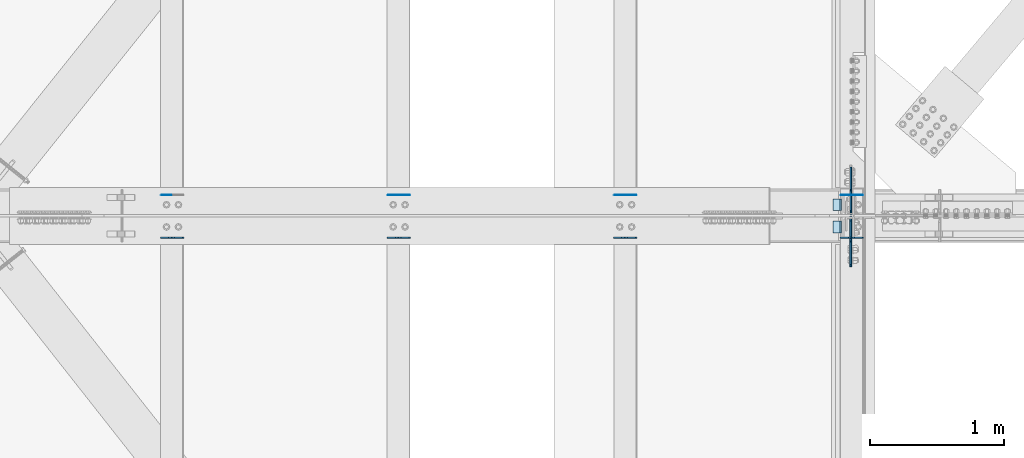
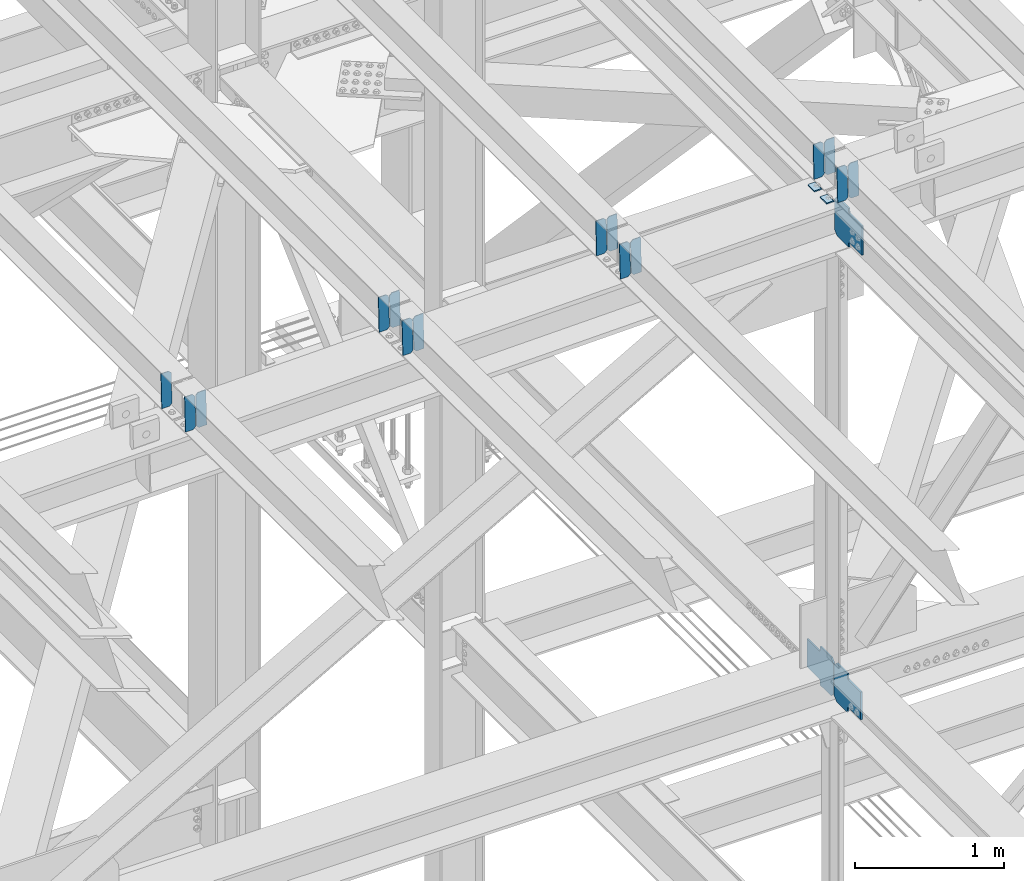
# One storey, part 3489 of 3843: 20 plates, 10 elements without a shape of their own.
"""IFC2X3 building model written with IfcOpenShell, lengths in millimetres."""

from ifc_helpers import new_model, si_unit, frame, origin_with_axes, place, context, subcontext, project, spatial, faceted_brep, material, type_object, element, aggregate, save


model = new_model("IFC2X3")

# Units and contexts
model_context = context("Model", 3, precision=1e-05, world=origin_with_axes())
body_context = subcontext(model_context, "Body", "Model", "MODEL_VIEW")
ifc_project = project(units=[si_unit("LENGTHUNIT", "METRE", prefix="MILLI"), si_unit("AREAUNIT", "SQUARE_METRE"), si_unit("VOLUMEUNIT", "CUBIC_METRE"), si_unit("MASSUNIT", "GRAM", prefix="KILO"), si_unit("TIMEUNIT", "SECOND"), si_unit("PLANEANGLEUNIT", "RADIAN"), si_unit("SOLIDANGLEUNIT", "STERADIAN"), si_unit("THERMODYNAMICTEMPERATUREUNIT", "DEGREE_CELSIUS"), si_unit("LUMINOUSINTENSITYUNIT", "LUMEN")], contexts=[model_context])

# Site, building, storey
site_placement = place(None, origin_with_axes())
site = spatial("IfcSite", under=ifc_project, at=site_placement, CompositionType="ELEMENT")
building_placement = place(site_placement, origin_with_axes())
building = spatial("IfcBuilding", under=site, at=building_placement, Name="Undefined", CompositionType="ELEMENT")
storey_placement = place(building_placement, origin_with_axes())
storey = spatial("IfcBuildingStorey", under=building, at=storey_placement, Name="Undefined", CompositionType="ELEMENT", Elevation=0.0)

# Assembly, plates
assembly_1_placement = place(storey_placement, origin_with_axes())
assembly_1 = element("IfcElementAssembly", 1, at=assembly_1_placement, inside=storey, Name="BEAM", AssemblyPlace="NOTDEFINED", PredefinedType="RIGID_FRAME")
ifc_material = material(Name="STEEL/A572-50")
plate_type_1 = type_object("IfcPlateType", PredefinedType="NOTDEFINED")
plate_1_placement = place(assembly_1_placement, frame((75405.9964783262, 84140.0711060768, 46268.5763166903), z_axis=(-0.021152098282546, 0.00202235899982043, 0.99977422391374), x_axis=(-0.999776269341419, -4.278700010456e-05, -0.0211520550071887)))
plate_1 = element("IfcPlate", 2, at=plate_1_placement, type_object=plate_type_1, material=ifc_material, Name="PLATE", context=body_context, shape_type="Brep", body=[
    faceted_brep([(0.0, -3.17499999999927, 0.0), (6.83940015733242e-10, -3.17499999996653, 288.924999998613), (6.54836185276508e-10, 3.17500000001746, 288.924999998591), (0.0, 3.17499999999927, 0.0), (60.3250007643655, -3.17500000017753, 288.924999998606), (60.3250007643219, 3.17499999979918, 288.924999998584), (79.3750000013097, -3.17500000025029, 269.875000761494), (79.375000001266, 3.17499999972642, 269.875000761487), (79.375000000713, -3.17500000026484, 19.0499992370605), (79.3750000006985, 3.17499999971187, 19.0499992370533), (60.325000763667, -3.17500000020664, -1.45519152283669e-11), (60.3250007636234, 3.17499999977736, -3.63797880709171e-11)], [[[0, 1, 2, 3]], [[1, 4, 5, 2]], [[4, 6, 7, 5]], [[6, 8, 9, 7]], [[8, 10, 11, 9]], [[10, 0, 3, 11]], [[5, 7, 9, 11, 3, 2]], [[10, 8, 6, 4, 1, 0]]]),
])
plate_2_placement = place(assembly_1_placement, frame((75320.2906576359, 84140.0674381852, 46266.7630567993), z_axis=(-0.021152098282546, 0.00202235899982043, 0.99977422391374), x_axis=(-0.999776269341419, -4.278700010456e-05, -0.0211520550071887)))
plate_2 = element("IfcPlate", 3, at=plate_2_placement, type_object=plate_type_1, material=ifc_material, Name="PLATE", context=body_context, shape_type="Brep", body=[
    faceted_brep([(4.36557456851006e-11, -3.17499999998836, 19.0499992370969), (6.11180439591408e-10, -3.17499999996653, 269.875000761516), (5.96628524363041e-10, 3.17500000001746, 269.875000761502), (1.45519152283669e-11, 3.17499999998836, 19.0499992370824), (19.0499992376572, -3.17500000003201, 288.924999998606), (19.0499992376281, 3.1749999999447, 288.924999998584), (79.3750000013242, -3.17500000025029, 288.924999998591), (79.3750000013097, 3.1749999997337, 288.92499999857), (79.3750000006548, -3.17500000026484, -2.18278728425503e-11), (79.3750000006403, 3.17499999969732, -2.91038304567337e-11), (19.0499992370023, -3.17500000005384, 0.0), (19.0499992369587, 3.17499999992287, -1.45519152283669e-11)], [[[0, 1, 2, 3]], [[1, 4, 5, 2]], [[4, 6, 7, 5]], [[6, 8, 9, 7]], [[8, 10, 11, 9]], [[10, 0, 3, 11]], [[5, 7, 9, 11, 3, 2]], [[10, 8, 6, 4, 1, 0]]]),
])
aggregate(assembly_1, [plate_1, plate_2])

assembly_2_placement = place(storey_placement, origin_with_axes())
assembly_2 = element("IfcElementAssembly", 4, at=assembly_2_placement, inside=storey, Name="BEAM", AssemblyPlace="NOTDEFINED", PredefinedType="RIGID_FRAME")
plate_3_placement = place(assembly_2_placement, frame((75405.9964783329, 83821.1587138441, 46270.8205939202), z_axis=(-0.0211520977145119, 0.00680309599898463, 0.999753122849388), x_axis=(-0.999776269353437, -0.000143932000051449, -0.0211516080075169)))
plate_3 = element("IfcPlate", 5, at=plate_3_placement, type_object=plate_type_1, material=ifc_material, Name="PLATE", context=body_context, shape_type="Brep", body=[
    faceted_brep([(0.0, -3.17499999999927, 0.0), (6.83940015733242e-10, -3.17499999996653, 288.924999998613), (6.54836185276508e-10, 3.17500000001746, 288.924999998591), (0.0, 3.17499999999927, 0.0), (60.3250007643655, -3.17500000017753, 288.924999998606), (60.3250007643219, 3.17499999979918, 288.924999998584), (79.3750000013097, -3.17500000025029, 269.875000761494), (79.375000001266, 3.17499999972642, 269.875000761487), (79.375000000713, -3.17500000026484, 19.0499992370605), (79.3750000006985, 3.17499999971187, 19.0499992370533), (60.325000763667, -3.17500000020664, -1.45519152283669e-11), (60.3250007636234, 3.17499999977736, -3.63797880709171e-11)], [[[0, 1, 2, 3]], [[1, 4, 5, 2]], [[4, 6, 7, 5]], [[6, 8, 9, 7]], [[8, 10, 11, 9]], [[10, 0, 3, 11]], [[5, 7, 9, 11, 3, 2]], [[10, 8, 6, 4, 1, 0]]]),
])
plate_4_placement = place(assembly_2_placement, frame((75320.2906576427, 83821.1463752781, 46269.0073722994), z_axis=(-0.0211520977145119, 0.00680309599898463, 0.999753122849388), x_axis=(-0.999776269353437, -0.000143932000051449, -0.0211516080075169)))
plate_4 = element("IfcPlate", 6, at=plate_4_placement, type_object=plate_type_1, material=ifc_material, Name="PLATE", context=body_context, shape_type="Brep", body=[
    faceted_brep([(4.36557456851006e-11, -3.17499999998836, 19.0499992370969), (6.11180439591408e-10, -3.17499999996653, 269.875000761516), (5.96628524363041e-10, 3.17500000001746, 269.875000761502), (1.45519152283669e-11, 3.17499999998836, 19.0499992370824), (19.0499992376572, -3.17500000003201, 288.924999998606), (19.0499992376281, 3.1749999999447, 288.924999998584), (79.3750000013242, -3.17500000025029, 288.924999998591), (79.3750000013097, 3.1749999997337, 288.92499999857), (79.3750000006548, -3.17500000026484, -2.18278728425503e-11), (79.3750000006403, 3.17499999969732, -2.91038304567337e-11), (19.0499992370023, -3.17500000005384, 0.0), (19.0499992369587, 3.17499999992287, -1.45519152283669e-11)], [[[0, 1, 2, 3]], [[1, 4, 5, 2]], [[4, 6, 7, 5]], [[6, 8, 9, 7]], [[8, 10, 11, 9]], [[10, 0, 3, 11]], [[5, 7, 9, 11, 3, 2]], [[10, 8, 6, 4, 1, 0]]]),
])
aggregate(assembly_2, [plate_3, plate_4])

assembly_3_placement = place(storey_placement, origin_with_axes())
assembly_3 = element("IfcElementAssembly", 7, at=assembly_3_placement, inside=storey, Name="BEAM", AssemblyPlace="NOTDEFINED", PredefinedType="RIGID_FRAME")
plate_5_placement = place(assembly_3_placement, frame((77095.0964787, 84140.0262572137, 46305.9190726986), z_axis=(-0.021152097941289, 0.00217238000044017, 0.999773909200383), x_axis=(-0.999776269356297, -4.57939999836346e-05, -0.021152048007558)))
plate_5 = element("IfcPlate", 8, at=plate_5_placement, type_object=plate_type_1, material=ifc_material, Name="PLATE", context=body_context, shape_type="Brep", body=[
    faceted_brep([(0.0, -3.17499999999927, 0.0), (6.83940015733242e-10, -3.17499999996653, 288.924999998613), (6.54836185276508e-10, 3.17500000001746, 288.924999998591), (0.0, 3.17499999999927, 0.0), (60.3250007643655, -3.17500000017753, 288.924999998606), (60.3250007643219, 3.17499999979918, 288.924999998584), (79.3750000013097, -3.17500000025029, 269.875000761494), (79.375000001266, 3.17499999972642, 269.875000761487), (79.375000000713, -3.17500000026484, 19.0499992370605), (79.3750000006985, 3.17499999971187, 19.0499992370533), (60.325000763667, -3.17500000020664, -1.45519152283669e-11), (60.3250007636234, 3.17499999977736, -3.63797880709171e-11)], [[[0, 1, 2, 3]], [[1, 4, 5, 2]], [[4, 6, 7, 5]], [[6, 8, 9, 7]], [[8, 10, 11, 9]], [[10, 0, 3, 11]], [[5, 7, 9, 11, 3, 2]], [[10, 8, 6, 4, 1, 0]]]),
])
plate_6_placement = place(assembly_3_placement, frame((77009.3906580087, 84140.0223172339, 46304.1058133777), z_axis=(-0.021152097941289, 0.00217238000044017, 0.999773909200383), x_axis=(-0.999776269356297, -4.57939999836346e-05, -0.021152048007558)))
plate_6 = element("IfcPlate", 9, at=plate_6_placement, type_object=plate_type_1, material=ifc_material, Name="PLATE", context=body_context, shape_type="Brep", body=[
    faceted_brep([(4.36557456851006e-11, -3.17499999998836, 19.0499992370969), (6.11180439591408e-10, -3.17499999996653, 269.875000761516), (5.96628524363041e-10, 3.17500000001746, 269.875000761502), (1.45519152283669e-11, 3.17499999998836, 19.0499992370824), (19.0499992376572, -3.17500000003201, 288.924999998606), (19.0499992376281, 3.1749999999447, 288.924999998584), (79.3750000013242, -3.17500000025029, 288.924999998591), (79.3750000013097, 3.1749999997337, 288.92499999857), (79.3750000006548, -3.17500000026484, -2.18278728425503e-11), (79.3750000006403, 3.17499999969732, -2.91038304567337e-11), (19.0499992370023, -3.17500000005384, 0.0), (19.0499992369587, 3.17499999992287, -1.45519152283669e-11)], [[[0, 1, 2, 3]], [[1, 4, 5, 2]], [[4, 6, 7, 5]], [[6, 8, 9, 7]], [[8, 10, 11, 9]], [[10, 0, 3, 11]], [[5, 7, 9, 11, 3, 2]], [[10, 8, 6, 4, 1, 0]]]),
])

assembly_4_placement = place(storey_placement, origin_with_axes())
assembly_4 = element("IfcElementAssembly", 10, at=assembly_4_placement, inside=storey, Name="BEAM", AssemblyPlace="NOTDEFINED", PredefinedType="RIGID_FRAME")
plate_7_placement = place(assembly_4_placement, frame((77095.0964779665, 83821.2714259354, 46307.3053200419), z_axis=(-0.0211520979147317, 0.00640378100221278, 0.999755760344836), x_axis=(-0.999776269349201, -0.000135484000106306, -0.02115166400736)))
plate_7 = element("IfcPlate", 11, at=plate_7_placement, type_object=plate_type_1, material=ifc_material, Name="PLATE", context=body_context, shape_type="Brep", body=[
    faceted_brep([(0.0, -3.17499999999927, 0.0), (6.83940015733242e-10, -3.17499999996653, 288.924999998613), (6.54836185276508e-10, 3.17500000001746, 288.924999998591), (0.0, 3.17499999999927, 0.0), (60.3250007643655, -3.17500000017753, 288.924999998606), (60.3250007643219, 3.17499999979918, 288.924999998584), (79.3750000013097, -3.17500000025029, 269.875000761494), (79.375000001266, 3.17499999972642, 269.875000761487), (79.375000000713, -3.17500000026484, 19.0499992370605), (79.3750000006985, 3.17499999971187, 19.0499992370533), (60.325000763667, -3.17500000020664, -1.45519152283669e-11), (60.3250007636234, 3.17499999977736, -3.63797880709171e-11)], [[[0, 1, 2, 3]], [[1, 4, 5, 2]], [[4, 6, 7, 5]], [[6, 8, 9, 7]], [[8, 10, 11, 9]], [[10, 0, 3, 11]], [[5, 7, 9, 11, 3, 2]], [[10, 8, 6, 4, 1, 0]]]),
])
plate_8_placement = place(assembly_4_placement, frame((77009.3906572761, 83821.259811594, 46305.4920936373), z_axis=(-0.0211520979147317, 0.00640378100221278, 0.999755760344836), x_axis=(-0.999776269349201, -0.000135484000106306, -0.02115166400736)))
plate_8 = element("IfcPlate", 12, at=plate_8_placement, type_object=plate_type_1, material=ifc_material, Name="PLATE", context=body_context, shape_type="Brep", body=[
    faceted_brep([(4.36557456851006e-11, -3.17499999998836, 19.0499992370969), (6.11180439591408e-10, -3.17499999996653, 269.875000761516), (5.96628524363041e-10, 3.17500000001746, 269.875000761502), (1.45519152283669e-11, 3.17499999998836, 19.0499992370824), (19.0499992376572, -3.17500000003201, 288.924999998606), (19.0499992376281, 3.1749999999447, 288.924999998584), (79.3750000013242, -3.17500000025029, 288.924999998591), (79.3750000013097, 3.1749999997337, 288.92499999857), (79.3750000006548, -3.17500000026484, -2.18278728425503e-11), (79.3750000006403, 3.17499999969732, -2.91038304567337e-11), (19.0499992370023, -3.17500000005384, 0.0), (19.0499992369587, 3.17499999992287, -1.45519152283669e-11)], [[[0, 1, 2, 3]], [[1, 4, 5, 2]], [[4, 6, 7, 5]], [[6, 8, 9, 7]], [[8, 10, 11, 9]], [[10, 0, 3, 11]], [[5, 7, 9, 11, 3, 2]], [[10, 8, 6, 4, 1, 0]]]),
])

assembly_5_placement = place(storey_placement, origin_with_axes())
assembly_5 = element("IfcElementAssembly", 13, at=assembly_5_placement, inside=storey, Name="BEAM", AssemblyPlace="NOTDEFINED", PredefinedType="RIGID_FRAME")
plate_9_placement = place(assembly_5_placement, frame((73716.8964783457, 84140.0711060764, 46232.8402990522), z_axis=(-0.021152098282546, 0.00202235899982043, 0.99977422391374), x_axis=(-0.999776269341419, -4.278700010456e-05, -0.0211520550071887)))
plate_9 = element("IfcPlate", 14, at=plate_9_placement, type_object=plate_type_1, material=ifc_material, Name="PLATE", context=body_context, shape_type="Brep", body=[
    faceted_brep([(0.0, -3.17499999999927, 0.0), (6.83940015733242e-10, -3.17499999996653, 288.924999998613), (6.54836185276508e-10, 3.17500000001746, 288.924999998591), (0.0, 3.17499999999927, 0.0), (60.3250007643655, -3.17500000017753, 288.924999998606), (60.3250007643219, 3.17499999979918, 288.924999998584), (79.3750000013097, -3.17500000025029, 269.875000761494), (79.375000001266, 3.17499999972642, 269.875000761487), (79.375000000713, -3.17500000026484, 19.0499992370605), (79.3750000006985, 3.17499999971187, 19.0499992370533), (60.325000763667, -3.17500000020664, -1.45519152283669e-11), (60.3250007636234, 3.17499999977736, -3.63797880709171e-11)], [[[0, 1, 2, 3]], [[1, 4, 5, 2]], [[4, 6, 7, 5]], [[6, 8, 9, 7]], [[8, 10, 11, 9]], [[10, 0, 3, 11]], [[5, 7, 9, 11, 3, 2]], [[10, 8, 6, 4, 1, 0]]]),
])
plate_10_placement = place(assembly_5_placement, frame((73631.1906576545, 84140.0674381851, 46231.0270391614), z_axis=(-0.021152098282546, 0.00202235899982043, 0.99977422391374), x_axis=(-0.999776269341419, -4.278700010456e-05, -0.0211520550071887)))
plate_10 = element("IfcPlate", 15, at=plate_10_placement, type_object=plate_type_1, material=ifc_material, Name="PLATE", context=body_context, shape_type="Brep", body=[
    faceted_brep([(4.36557456851006e-11, -3.17499999998836, 19.0499992370969), (6.11180439591408e-10, -3.17499999996653, 269.875000761516), (5.96628524363041e-10, 3.17500000001746, 269.875000761502), (1.45519152283669e-11, 3.17499999998836, 19.0499992370824), (19.0499992376572, -3.17500000003201, 288.924999998606), (19.0499992376281, 3.1749999999447, 288.924999998584), (79.3750000013242, -3.17500000025029, 288.924999998591), (79.3750000013097, 3.1749999997337, 288.92499999857), (79.3750000006548, -3.17500000026484, -2.18278728425503e-11), (79.3750000006403, 3.17499999969732, -2.91038304567337e-11), (19.0499992370023, -3.17500000005384, 0.0), (19.0499992369587, 3.17499999992287, -1.45519152283669e-11)], [[[0, 1, 2, 3]], [[1, 4, 5, 2]], [[4, 6, 7, 5]], [[6, 8, 9, 7]], [[8, 10, 11, 9]], [[10, 0, 3, 11]], [[5, 7, 9, 11, 3, 2]], [[10, 8, 6, 4, 1, 0]]]),
])
aggregate(assembly_5, [plate_9, plate_10])

assembly_6_placement = place(storey_placement, origin_with_axes())
assembly_6 = element("IfcElementAssembly", 16, at=assembly_6_placement, inside=storey, Name="BEAM", AssemblyPlace="NOTDEFINED", PredefinedType="RIGID_FRAME")
plate_11_placement = place(assembly_6_placement, frame((73716.8964783357, 83821.0523074194, 46234.3262938903), z_axis=(-0.0211520979914349, 0.0071438070022996, 0.999750746322339), x_axis=(-0.999776269347578, -0.000151140000075321, -0.021151558007389)))
plate_11 = element("IfcPlate", 17, at=plate_11_placement, type_object=plate_type_1, material=ifc_material, Name="PLATE", context=body_context, shape_type="Brep", body=[
    faceted_brep([(0.0, -3.17499999999927, 0.0), (6.83940015733242e-10, -3.17499999996653, 288.924999998613), (6.54836185276508e-10, 3.17500000001746, 288.924999998591), (0.0, 3.17499999999927, 0.0), (60.3250007643655, -3.17500000017753, 288.924999998606), (60.3250007643219, 3.17499999979918, 288.924999998584), (79.3750000013097, -3.17500000025029, 269.875000761494), (79.375000001266, 3.17499999972642, 269.875000761487), (79.375000000713, -3.17500000026484, 19.0499992370605), (79.3750000006985, 3.17499999971187, 19.0499992370533), (60.325000763667, -3.17500000020664, -1.45519152283669e-11), (60.3250007636234, 3.17499999977736, -3.63797880709171e-11)], [[[0, 1, 2, 3]], [[1, 4, 5, 2]], [[4, 6, 7, 5]], [[6, 8, 9, 7]], [[8, 10, 11, 9]], [[10, 0, 3, 11]], [[5, 7, 9, 11, 3, 2]], [[10, 8, 6, 4, 1, 0]]]),
])
plate_12_placement = place(assembly_6_placement, frame((73631.1906576445, 83821.0393509136, 46232.5130765786), z_axis=(-0.0211520979914349, 0.0071438070022996, 0.999750746322339), x_axis=(-0.999776269347578, -0.000151140000075321, -0.021151558007389)))
plate_12 = element("IfcPlate", 18, at=plate_12_placement, type_object=plate_type_1, material=ifc_material, Name="PLATE", context=body_context, shape_type="Brep", body=[
    faceted_brep([(4.36557456851006e-11, -3.17499999998836, 19.0499992370969), (6.11180439591408e-10, -3.17499999996653, 269.875000761516), (5.96628524363041e-10, 3.17500000001746, 269.875000761502), (1.45519152283669e-11, 3.17499999998836, 19.0499992370824), (19.0499992376572, -3.17500000003201, 288.924999998606), (19.0499992376281, 3.1749999999447, 288.924999998584), (79.3750000013242, -3.17500000025029, 288.924999998591), (79.3750000013097, 3.1749999997337, 288.92499999857), (79.3750000006548, -3.17500000026484, -2.18278728425503e-11), (79.3750000006403, 3.17499999969732, -2.91038304567337e-11), (19.0499992370023, -3.17500000005384, 0.0), (19.0499992369587, 3.17499999992287, -1.45519152283669e-11)], [[[0, 1, 2, 3]], [[1, 4, 5, 2]], [[4, 6, 7, 5]], [[6, 8, 9, 7]], [[8, 10, 11, 9]], [[10, 0, 3, 11]], [[5, 7, 9, 11, 3, 2]], [[10, 8, 6, 4, 1, 0]]]),
])
aggregate(assembly_6, [plate_11, plate_12])

# Assembly, plate
assembly_7_placement = place(storey_placement, origin_with_axes())
assembly_7 = element("IfcElementAssembly", 19, at=assembly_7_placement, inside=storey, Name="BEAM", AssemblyPlace="NOTDEFINED", PredefinedType="RIGID_FRAME")
plate_13_placement = place(assembly_7_placement, frame((71942.0906576562, 84140.0951581345, 46194.4903064654), z_axis=(-0.0211520984278759, 0.00193018200022925, 0.999774406118472), x_axis=(-0.999776269338344, -4.08370000134752e-05, -0.0211520590071558)))
plate_13 = element("IfcPlate", 20, at=plate_13_placement, type_object=plate_type_1, material=ifc_material, Name="PLATE", context=body_context, shape_type="Brep", body=[
    faceted_brep([(4.36557456851006e-11, -3.17499999998836, 19.0499992370969), (6.11180439591408e-10, -3.17499999996653, 269.875000761516), (5.96628524363041e-10, 3.17500000001746, 269.875000761502), (1.45519152283669e-11, 3.17499999998836, 19.0499992370824), (19.0499992376572, -3.17500000003201, 288.924999998606), (19.0499992376281, 3.1749999999447, 288.924999998584), (79.3750000013242, -3.17500000025029, 288.924999998591), (79.3750000013097, 3.1749999997337, 288.92499999857), (79.3750000006548, -3.17500000026484, -2.18278728425503e-11), (79.3750000006403, 3.17499999969732, -2.91038304567337e-11), (19.0499992370023, -3.17500000005384, 0.0), (19.0499992369587, 3.17499999992287, -1.45519152283669e-11)], [[[0, 1, 2, 3]], [[1, 4, 5, 2]], [[4, 6, 7, 5]], [[6, 8, 9, 7]], [[8, 10, 11, 9]], [[10, 0, 3, 11]], [[5, 7, 9, 11, 3, 2]], [[10, 8, 6, 4, 1, 0]]]),
])
aggregate(assembly_7, [plate_13])

# Assembly, plates
assembly_8_placement = place(storey_placement, origin_with_axes())
assembly_8 = element("IfcElementAssembly", 21, at=assembly_8_placement, inside=storey, Name="BEAM", AssemblyPlace="NOTDEFINED", PredefinedType="RIGID_FRAME")
plate_14_placement = place(assembly_8_placement, frame((72027.7964783034, 83820.9710279088, 46197.8210283002), z_axis=(-0.0211520983124356, 0.00741846499993701, 0.999748745992725), x_axis=(-0.999776269340787, -0.000156951000117703, -0.0211515160071882)))
plate_14 = element("IfcPlate", 22, at=plate_14_placement, type_object=plate_type_1, material=ifc_material, Name="PLATE", context=body_context, shape_type="Brep", body=[
    faceted_brep([(0.0, -3.17499999999927, 0.0), (6.83940015733242e-10, -3.17499999996653, 288.924999998613), (6.54836185276508e-10, 3.17500000001746, 288.924999998591), (0.0, 3.17499999999927, 0.0), (60.3250007643655, -3.17500000017753, 288.924999998606), (60.3250007643219, 3.17499999979918, 288.924999998584), (79.3750000013097, -3.17500000025029, 269.875000761494), (79.375000001266, 3.17499999972642, 269.875000761487), (79.375000000713, -3.17500000026484, 19.0499992370605), (79.3750000006985, 3.17499999971187, 19.0499992370533), (60.325000763667, -3.17500000020664, -1.45519152283669e-11), (60.3250007636234, 3.17499999977736, -3.63797880709171e-11)], [[[0, 1, 2, 3]], [[1, 4, 5, 2]], [[4, 6, 7, 5]], [[6, 8, 9, 7]], [[8, 10, 11, 9]], [[10, 0, 3, 11]], [[5, 7, 9, 11, 3, 2]], [[10, 8, 6, 4, 1, 0]]]),
])
plate_15_placement = place(assembly_8_placement, frame((71942.0906576122, 83820.9575732667, 46196.007814618), z_axis=(-0.0211520983124356, 0.00741846499993701, 0.999748745992725), x_axis=(-0.999776269340787, -0.000156951000117703, -0.0211515160071882)))
plate_15 = element("IfcPlate", 23, at=plate_15_placement, type_object=plate_type_1, material=ifc_material, Name="PLATE", context=body_context, shape_type="Brep", body=[
    faceted_brep([(4.36557456851006e-11, -3.17499999998836, 19.0499992370969), (6.11180439591408e-10, -3.17499999996653, 269.875000761516), (5.96628524363041e-10, 3.17500000001746, 269.875000761502), (1.45519152283669e-11, 3.17499999998836, 19.0499992370824), (19.0499992376572, -3.17500000003201, 288.924999998606), (19.0499992376281, 3.1749999999447, 288.924999998584), (79.3750000013242, -3.17500000025029, 288.924999998591), (79.3750000013097, 3.1749999997337, 288.92499999857), (79.3750000006548, -3.17500000026484, -2.18278728425503e-11), (79.3750000006403, 3.17499999969732, -2.91038304567337e-11), (19.0499992370023, -3.17500000005384, 0.0), (19.0499992369587, 3.17499999992287, -1.45519152283669e-11)], [[[0, 1, 2, 3]], [[1, 4, 5, 2]], [[4, 6, 7, 5]], [[6, 8, 9, 7]], [[8, 10, 11, 9]], [[10, 0, 3, 11]], [[5, 7, 9, 11, 3, 2]], [[10, 8, 6, 4, 1, 0]]]),
])
aggregate(assembly_8, [plate_14, plate_15])

# Plate
plate_type_2 = type_object("IfcPlateType", PredefinedType="NOTDEFINED")
plate_16_placement = place(assembly_3_placement, frame((76930.1677232886, 84112.0999999999, 46296.4153296551), z_axis=(0.0, -1.0, 0.0), x_axis=(-0.999776270257024, 0.0, -0.0211520550054595)))
plate_16 = element("IfcPlate", 24, at=plate_16_placement, type_object=plate_type_2, material=ifc_material, Name="PLATE", context=body_context, shape_type="Brep", body=[
    faceted_brep([(9.52499999982683, -4.7625000001135, 88.8999999999942), (0.0, 4.76249999999709, 88.9000015258789), (0.0, 4.76249999999709, 0.0), (9.52499999981956, -4.76249999999709, 0.0), (63.4999984608512, -4.76249999988795, 88.8999999999796), (63.4999984608367, -4.76249999988795, -1.45519152283669e-11), (63.4999984608221, 4.76250000013533, -1.45519152283669e-11), (63.4999984608367, 4.76250000013533, 88.8999999999796)], [[[0, 1, 2, 3]], [[4, 5, 6, 7]], [[5, 4, 0, 3]], [[6, 5, 3, 2]], [[7, 6, 2, 1]], [[4, 7, 1, 0]]]),
])

aggregate(assembly_3, [plate_5, plate_6, plate_16])

plate_17_placement = place(assembly_4_placement, frame((76930.1677232886, 83947.0000015258, 46296.4153296551), z_axis=(0.0, -1.0, 0.0), x_axis=(-0.999776270257024, 0.0, -0.0211520550054595)))
plate_17 = element("IfcPlate", 25, at=plate_17_placement, type_object=plate_type_2, material=ifc_material, Name="PLATE", context=body_context, shape_type="Brep", body=[
    faceted_brep([(9.52499999982683, -4.7625000001135, 88.8999999999942), (0.0, 4.76249999999709, 88.9000015258789), (0.0, 4.76249999999709, 0.0), (9.52499999981956, -4.76249999999709, 0.0), (63.4999984608512, -4.76249999988795, 88.8999999999796), (63.4999984608367, -4.76249999988795, -1.45519152283669e-11), (63.4999984608221, 4.76250000013533, -1.45519152283669e-11), (63.4999984608367, 4.76250000013533, 88.8999999999796)], [[[0, 1, 2, 3]], [[4, 5, 6, 7]], [[5, 4, 0, 3]], [[6, 5, 3, 2]], [[7, 6, 2, 1]], [[4, 7, 1, 0]]]),
])

aggregate(assembly_4, [plate_7, plate_8, plate_17])

# Assembly, plates
assembly_9_placement = place(storey_placement, origin_with_axes())
assembly_9 = element("IfcElementAssembly", 26, at=assembly_9_placement, inside=storey, Name="BEAM", AssemblyPlace="NOTDEFINED", PredefinedType="RIGID_FRAME")
plate_type_3 = type_object("IfcPlateType", PredefinedType="NOTDEFINED")
plate_18_placement = place(assembly_9_placement, frame((77000.0999997037, 83977.9562500612, 42139.0704067988), z_axis=(0.0, -0.707106781186682, 0.707106781186413), x_axis=(0.0, -0.707106781186548, -0.707106781186548)))
plate_18 = element("IfcPlate", 27, at=plate_18_placement, type_object=plate_type_3, material=ifc_material, Name="PLATE", context=body_context, shape_type="Brep", body=[
    faceted_brep([(0.0, -6.3499999046162, 0.0), (-179.600813047069, -6.35000000000582, 179.600813047073), (-179.600813047069, 6.35000000000582, 179.600813047073), (7.27595761418343e-12, 6.3499999046162, 0.0), (-179.600813047073, -6.35000000000582, 224.502093652191), (-179.600813047073, 6.35000000000582, 224.502093652191), (-75.7666016477051, -6.35000000000582, 328.336305051562), (-75.7666016477051, 6.35000000000582, 328.336305051562), (-54.423873286185, -6.35000000000582, 306.993576781922), (-54.423873286185, 6.35000000000582, 306.993576781922), (-50.303696818024, -6.35000000000582, 304.240562881463), (-50.303696818024, 6.35000000000582, 304.240562881463), (-45.4436172999704, -6.35000000000582, 303.273832958894), (-45.4436172999704, 6.35000000000582, 303.273832958894), (-40.5835377819167, -6.35000000000582, 304.24056288151), (-40.5835377819167, 6.35000000000582, 304.24056288151), (-36.4633613137266, -6.35000000000582, 306.993576782017), (-36.4633613137266, 6.35000000000582, 306.993576782017), (80.2799683536141, -6.35000000000582, 423.736906449365), (80.2799683536141, 6.35000000000582, 423.736906449365), (241.924578532067, -6.35000000000582, 262.092296270883), (241.924578532067, 6.35000000000582, 262.092296270883), (125.181248864727, -6.35000000000582, 145.348966603549), (125.181248864727, 6.35000000000582, 145.348966603549), (122.428234964231, -6.35000000000582, 141.228790135367), (122.428234964231, 6.35000000000582, 141.228790135367), (121.461505041618, -6.35000000000582, 136.368710617306), (121.461505041618, 6.35000000000582, 136.368710617306), (122.428234964187, -6.35000000000582, 131.508631099252), (122.428234964187, 6.35000000000582, 131.508631099252), (125.181248864639, -6.35000000000582, 127.388454631098), (125.181248864639, 6.35000000000582, 127.388454631098), (148.735492004496, -6.35000000000582, 103.834211399357), (148.735492004496, 6.35000000000582, 103.834211399357), (44.9012806051323, -6.35000000000582, -1.45519152283669e-11), (44.9012806051323, 6.35000000000582, -1.45519152283669e-11)], [[[0, 1, 2, 3]], [[1, 4, 5, 2]], [[4, 6, 7, 5]], [[6, 8, 9, 7]], [[8, 10, 11, 9]], [[10, 12, 13, 11]], [[12, 14, 15, 13]], [[14, 16, 17, 15]], [[16, 18, 19, 17]], [[18, 20, 21, 19]], [[20, 22, 23, 21]], [[22, 24, 25, 23]], [[24, 26, 27, 25]], [[26, 28, 29, 27]], [[28, 30, 31, 29]], [[30, 32, 33, 31]], [[32, 34, 35, 33]], [[34, 0, 3, 35]], [[5, 7, 9, 11, 13, 15, 17, 19, 21, 23, 25, 27, 29, 31, 33, 35, 3, 2]], [[34, 32, 30, 28, 26, 24, 22, 20, 18, 16, 14, 12, 10, 8, 6, 4, 1, 0]]]),
])
plate_19_placement = place(assembly_9_placement, frame((77001.6874997356, 83992.24375, 42139.0711731725), z_axis=(0.0, 0.707106781186548, 0.707106781186548), x_axis=(5.70000238222118e-08, 0.707106781186546, -0.707106781186546)))
plate_19 = element("IfcPlate", 28, at=plate_19_placement, type_object=plate_type_3, material=ifc_material, Name="PLATE", context=body_context, shape_type="Brep", body=[
    faceted_brep([(0.0, -6.3499999046162, 0.0), (-179.600813047069, -6.35000000000582, 179.600813047073), (-179.600813047069, 6.35000000000582, 179.600813047073), (7.27595761418343e-12, 6.3499999046162, 0.0), (-179.600813047073, -6.35000000000582, 224.502093652191), (-179.600813047073, 6.35000000000582, 224.502093652191), (-75.7666016477051, -6.35000000000582, 328.336305051562), (-75.7666016477051, 6.35000000000582, 328.336305051562), (-52.668384245364, -6.35000000000582, 305.238087651742), (-52.668384245364, 6.35000000000582, 305.238087651742), (-48.5482077772176, -6.35000000000582, 302.485073751268), (-48.5482077772176, 6.35000000000582, 302.485073751268), (-43.6881282591785, -6.35000000000582, 301.518343828684), (-43.6881282591785, 6.35000000000582, 301.518343828684), (-38.8280487411539, -6.35000000000582, 302.485073751275), (-38.8280487411539, 6.35000000000582, 302.485073751275), (-34.7078722730075, -6.35000000000582, 305.238087651742), (-34.7078722730075, 6.35000000000582, 305.238087651742), (82.0354574365047, -6.35000000000582, 421.981417361261), (82.0354574365047, 6.35000000000582, 421.981417361261), (243.680067614972, -6.35000000000582, 260.336807182794), (243.680067614972, 6.35000000000582, 260.336807182794), (126.93673790546, -6.35000000000582, 143.593477473281), (126.93673790546, 6.35000000000582, 143.593477473281), (124.183724004986, -6.35000000000582, 139.473301005139), (124.183724004986, 6.35000000000582, 139.473301005139), (123.216994082402, -6.35000000000582, 134.613221487107), (123.216994082402, 6.35000000000582, 134.613221487107), (124.183724004994, -6.35000000000582, 129.753141969071), (124.183724004994, 6.35000000000582, 129.753141969071), (126.93673790546, -6.35000000000582, 125.632965500929), (126.93673790546, 6.35000000000582, 125.632965500929), (148.735492004496, -6.35000000000582, 103.834211399357), (148.735492004496, 6.35000000000582, 103.834211399357), (44.9012806051323, -6.35000000000582, -1.45519152283669e-11), (44.9012806051323, 6.35000000000582, -1.45519152283669e-11)], [[[0, 1, 2, 3]], [[1, 4, 5, 2]], [[4, 6, 7, 5]], [[6, 8, 9, 7]], [[8, 10, 11, 9]], [[10, 12, 13, 11]], [[12, 14, 15, 13]], [[14, 16, 17, 15]], [[16, 18, 19, 17]], [[18, 20, 21, 19]], [[20, 22, 23, 21]], [[22, 24, 25, 23]], [[24, 26, 27, 25]], [[26, 28, 29, 27]], [[28, 30, 31, 29]], [[30, 32, 33, 31]], [[32, 34, 35, 33]], [[34, 0, 3, 35]], [[5, 7, 9, 11, 13, 15, 17, 19, 21, 23, 25, 27, 29, 31, 33, 35, 3, 2]], [[34, 32, 30, 28, 26, 24, 22, 20, 18, 16, 14, 12, 10, 8, 6, 4, 1, 0]]]),
])
aggregate(assembly_9, [plate_18, plate_19])

# Assembly, plate
assembly_10_placement = place(storey_placement, origin_with_axes())
assembly_10 = element("IfcElementAssembly", 29, at=assembly_10_placement, inside=storey, Name="BEAM", AssemblyPlace="NOTDEFINED", PredefinedType="RIGID_FRAME")
plate_20_placement = place(assembly_10_placement, frame((77000.8937502343, 83973.9874999245, 45969.3457031156), z_axis=(0.0, -0.707106781186682, 0.707106781186413), x_axis=(0.0, -0.707106781186548, -0.707106781186548)))
plate_20 = element("IfcPlate", 30, at=plate_20_placement, type_object=plate_type_3, material=ifc_material, Name="PLATE", context=body_context, shape_type="Brep", body=[
    faceted_brep([(0.0, -6.3499999046162, 0.0), (-179.46387894213, -6.35000000000582, 179.46387894213), (-179.46387894213, 6.35000000000582, 179.46387894213), (7.27595761418343e-12, 6.3499999046162, 0.0), (-179.463878941897, -6.35000000000582, 224.365159547495), (-179.463878941897, 6.35000000000582, 224.365159547495), (-68.3332094431244, -6.35000000000582, 335.495829046271), (-68.3332094431244, 6.35000000000582, 335.495829046271), (-51.7903132426582, -6.35000000000582, 318.952932741831), (-51.7903132426582, 6.35000000000582, 318.952932741831), (-47.6701367745118, -6.35000000000582, 316.199918841372), (-47.6701367745118, 6.35000000000582, 316.199918841372), (-42.8100572564581, -6.35000000000582, 315.233188918803), (-42.8100572564581, 6.35000000000582, 315.233188918803), (-37.9499777383753, -6.35000000000582, 316.199918841416), (-37.9499777383753, 6.35000000000582, 316.199918841416), (-33.8298012701998, -6.35000000000582, 318.952932741926), (-33.8298012701998, 6.35000000000582, 318.952932741926), (82.9135284938675, -6.35000000000582, 435.696262506022), (82.9135284938675, 6.35000000000582, 435.696262506022), (253.538394793373, -6.35000000000582, 265.071396206549), (253.538394793373, 6.35000000000582, 265.071396206549), (136.795065029321, -6.35000000000582, 148.328066442446), (136.795065029321, 6.35000000000582, 148.328066442446), (134.04205112881, -6.35000000000582, 144.20788997427), (134.04205112881, 6.35000000000582, 144.20788997427), (133.075321206197, -6.35000000000582, 139.347810456216), (133.075321206197, 6.35000000000582, 139.347810456216), (134.042051128752, -6.35000000000582, 134.487730938155), (134.042051128752, 6.35000000000582, 134.487730938155), (136.795065029219, -6.35000000000582, 130.367554470002), (136.795065029219, 6.35000000000582, 130.367554470002), (156.031950102829, -6.35000000000582, 111.130669497703), (156.031950102829, 6.35000000000582, 111.130669497703), (44.9012806051323, -6.35000000000582, -1.45519152283669e-11), (44.9012806051323, 6.35000000000582, -1.45519152283669e-11)], [[[0, 1, 2, 3]], [[1, 4, 5, 2]], [[4, 6, 7, 5]], [[6, 8, 9, 7]], [[8, 10, 11, 9]], [[10, 12, 13, 11]], [[12, 14, 15, 13]], [[14, 16, 17, 15]], [[16, 18, 19, 17]], [[18, 20, 21, 19]], [[20, 22, 23, 21]], [[22, 24, 25, 23]], [[24, 26, 27, 25]], [[26, 28, 29, 27]], [[28, 30, 31, 29]], [[30, 32, 33, 31]], [[32, 34, 35, 33]], [[34, 0, 3, 35]], [[5, 7, 9, 11, 13, 15, 17, 19, 21, 23, 25, 27, 29, 31, 33, 35, 3, 2]], [[34, 32, 30, 28, 26, 24, 22, 20, 18, 16, 14, 12, 10, 8, 6, 4, 1, 0]]]),
])
aggregate(assembly_10, [plate_20])

save(model, "model.ifc")
